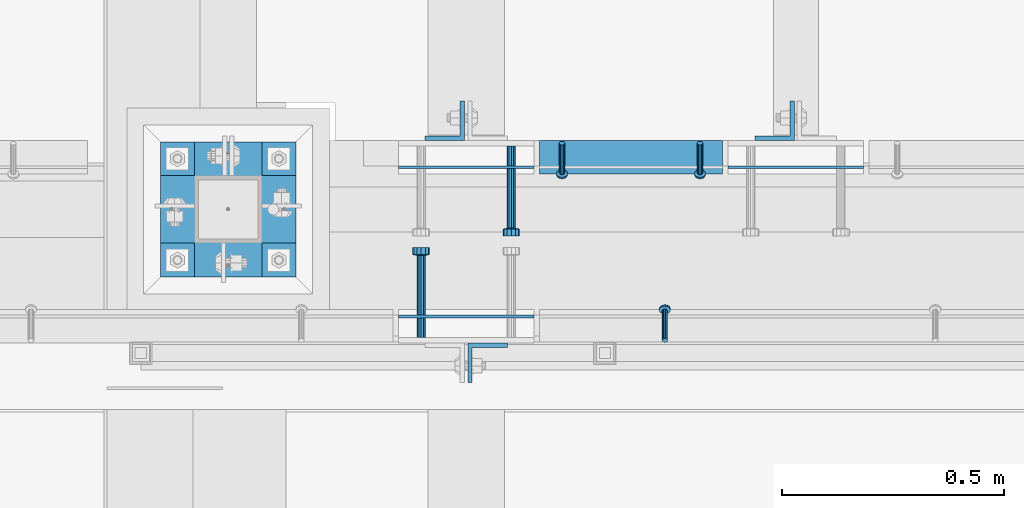
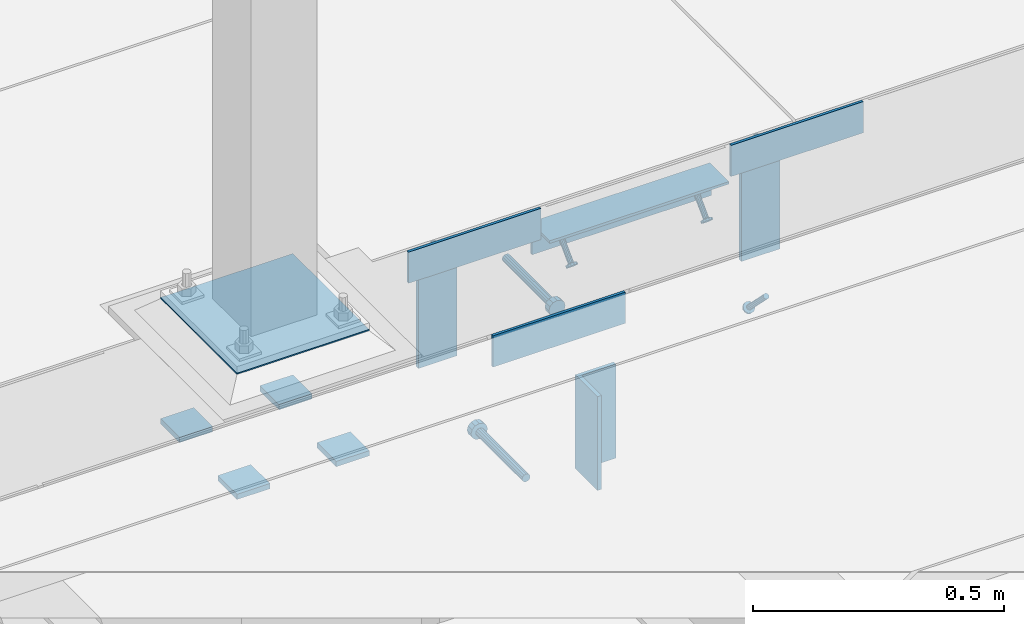
# One storey, part 2066 of 3843: 14 beams, 3 members, 9 elements without a shape of their own.
"""IFC2X3 building model written with IfcOpenShell, lengths in millimetres."""

from ifc_helpers import new_model, si_unit, frame, origin_with_axes, place, context, subcontext, project, spatial, faceted_brep, material, type_object, element, aggregate, save


model = new_model("IFC2X3")

# Units and contexts
model_context = context("Model", 3, precision=1e-05, world=origin_with_axes())
body_context = subcontext(model_context, "Body", "Model", "MODEL_VIEW")
ifc_project = project(units=[si_unit("LENGTHUNIT", "METRE", prefix="MILLI"), si_unit("AREAUNIT", "SQUARE_METRE"), si_unit("VOLUMEUNIT", "CUBIC_METRE"), si_unit("MASSUNIT", "GRAM", prefix="KILO"), si_unit("TIMEUNIT", "SECOND"), si_unit("PLANEANGLEUNIT", "RADIAN"), si_unit("SOLIDANGLEUNIT", "STERADIAN"), si_unit("THERMODYNAMICTEMPERATUREUNIT", "DEGREE_CELSIUS"), si_unit("LUMINOUSINTENSITYUNIT", "LUMEN")], contexts=[model_context])

# Site, building, storey
site_placement = place(None, origin_with_axes())
site = spatial("IfcSite", under=ifc_project, at=site_placement, CompositionType="ELEMENT")
building_placement = place(site_placement, origin_with_axes())
building = spatial("IfcBuilding", under=site, at=building_placement, Name="Undefined", CompositionType="ELEMENT")
storey_placement = place(building_placement, origin_with_axes())
storey = spatial("IfcBuildingStorey", under=building, at=storey_placement, Name="Undefined", CompositionType="ELEMENT", Elevation=0.0)

# Assembly, member
assembly_1_placement = place(storey_placement, origin_with_axes())
assembly_1 = element("IfcElementAssembly", 1, at=assembly_1_placement, inside=storey, Name="ANGLE", AssemblyPlace="NOTDEFINED", PredefinedType="RIGID_FRAME")
ifc_material_1 = material(Name="STEEL/A108")
member_type = type_object("IfcMemberType", PredefinedType="NOTDEFINED")
member_1_placement = place(assembly_1_placement, frame((49980.8497619755, 20012.0250010032, 30397.4500030497), z_axis=(-1.0, 0.0, 0.0), x_axis=(5.70000238222118e-08, 0.707106781186546, -0.707106781186546)))
member_1 = element("IfcMember", 2, at=member_1_placement, type_object=member_type, material=ifc_material_1, Name="HEADED STUD ANCHOR", context=body_context, shape_type="Brep", body=[
    faceted_brep([(7.27595761418343e-12, -3.18000006675175, 5.5), (0.0, -5.49999999998363, 3.1800000667572), (94.4879985803855, -5.50000000011278, 3.1800000667572), (94.4879985803782, -3.18000006687362, 5.5), (0.0, -6.3499999046162, 0.0), (94.4879985803855, -6.34999990474535, 0.0), (0.0, -5.49999999998363, -3.1800000667572), (94.4879985803855, -5.50000000011278, -3.1800000667572), (7.27595761418343e-12, -3.18000006675175, -5.5), (94.4879985803782, -3.18000006687362, -5.5), (7.27595761418343e-12, -1.81898940354586e-12, -6.34999990463257), (94.4879985803782, -1.20053300634027e-10, -6.34999990463257), (0.0, 3.18000006675175, -5.5), (94.4879985803709, 3.18000006663351, -5.5), (7.27595761418343e-12, 5.49999999998363, -3.1800000667572), (94.4879985803709, 5.49999999987267, -3.1800000667572), (7.27595761418343e-12, 6.3499999046162, 0.0), (94.4879985803673, 6.34999990450706, 0.0), (7.27595761418343e-12, 5.49999999998363, 3.1800000667572), (94.4879985803709, 5.49999999987267, 3.1800000667572), (0.0, 3.18000006675175, 5.5), (94.4879985803709, 3.18000006663351, 5.5), (7.27595761418343e-12, -1.81898940354586e-12, 6.34999990463257), (94.4879985803782, -1.20053300634027e-10, 6.34999990463257), (96.5199985498621, -10.9899997712273, 6.34999990463257), (96.5199985498548, -6.34000015270249, 10.9899997711182), (96.5199985498621, -12.6999998093743, 0.0), (96.5199985498621, -10.9899997712273, -6.34999990463257), (96.5199985498548, -6.34000015270249, -10.9899997711182), (96.5199985498475, -1.21872290037572e-10, -12.6899995803833), (96.5199985498402, 6.34000015245874, -10.9899997711182), (96.519998549833, 10.9899997709817, -6.34999990463257), (96.519998549833, 12.6999998091305, 0.0), (96.519998549833, 10.9899997709817, 6.34999990463257), (96.5199985498402, 6.34000015245874, 10.9899997711182), (96.5199985498475, -1.21872290037572e-10, 12.6899995803833), (101.599998473539, -10.9899997712328, 6.34999990463257), (101.599998473532, -6.34000015270976, 10.9899997711182), (101.599998473539, -12.6999998093797, 0.0), (101.599998473539, -10.9899997712328, -6.34999990463257), (101.599998473532, -6.34000015270976, -10.9899997711182), (101.599998473524, -1.29148247651756e-10, -12.6899995803833), (101.599998473517, 6.34000015245329, -10.9899997711182), (101.59999847351, 10.9899997709763, -6.34999990463257), (101.599998473503, 12.6999998091196, 0.0), (101.59999847351, 10.9899997709763, 6.34999990463257), (101.599998473517, 6.34000015245329, 10.9899997711182), (101.599998473524, -1.29148247651756e-10, 12.6899995803833)], [[[0, 1, 2, 3]], [[1, 4, 5, 2]], [[4, 6, 7, 5]], [[6, 8, 9, 7]], [[8, 10, 11, 9]], [[10, 12, 13, 11]], [[12, 14, 15, 13]], [[14, 16, 17, 15]], [[16, 18, 19, 17]], [[18, 20, 21, 19]], [[20, 22, 23, 21]], [[22, 0, 3, 23]], [[22, 20, 18, 16, 14, 12, 10, 8, 6, 4, 1, 0]], [[3, 2, 24, 25]], [[2, 5, 26, 24]], [[5, 7, 27, 26]], [[7, 9, 28, 27]], [[9, 11, 29, 28]], [[11, 13, 30, 29]], [[13, 15, 31, 30]], [[15, 17, 32, 31]], [[17, 19, 33, 32]], [[19, 21, 34, 33]], [[21, 23, 35, 34]], [[23, 3, 25, 35]], [[25, 24, 36, 37]], [[24, 26, 38, 36]], [[26, 27, 39, 38]], [[27, 28, 40, 39]], [[28, 29, 41, 40]], [[29, 30, 42, 41]], [[30, 31, 43, 42]], [[31, 32, 44, 43]], [[32, 33, 45, 44]], [[33, 34, 46, 45]], [[34, 35, 47, 46]], [[35, 25, 37, 47]], [[38, 39, 40, 41, 42, 43, 44, 45, 46, 47, 37, 36]]]),
])
aggregate(assembly_1, [member_1])

# Assembly, members
assembly_2_placement = place(storey_placement, origin_with_axes())
assembly_2 = element("IfcElementAssembly", 3, at=assembly_2_placement, inside=storey, Name="ANGLE", AssemblyPlace="NOTDEFINED", PredefinedType="RIGID_FRAME")
member_2_placement = place(assembly_2_placement, frame((49749.0749969224, 20456.5247895468, 30397.4500030518), z_axis=(1.0, 0.0, 0.0), x_axis=(0.0, -0.707106781186548, -0.707106781186548)))
member_2 = element("IfcMember", 4, at=member_2_placement, type_object=member_type, material=ifc_material_1, Name="HEADED STUD ANCHOR", context=body_context, shape_type="Brep", body=[
    faceted_brep([(7.27595761418343e-12, -3.18000006675175, 5.5), (0.0, -5.49999999998363, 3.1800000667572), (94.4879985803855, -5.50000000011278, 3.1800000667572), (94.4879985803782, -3.18000006687362, 5.5), (0.0, -6.3499999046162, 0.0), (94.4879985803855, -6.34999990474535, 0.0), (0.0, -5.49999999998363, -3.1800000667572), (94.4879985803855, -5.50000000011278, -3.1800000667572), (7.27595761418343e-12, -3.18000006675175, -5.5), (94.4879985803782, -3.18000006687362, -5.5), (7.27595761418343e-12, -1.81898940354586e-12, -6.34999990463257), (94.4879985803782, -1.20053300634027e-10, -6.34999990463257), (0.0, 3.18000006675175, -5.5), (94.4879985803709, 3.18000006663351, -5.5), (7.27595761418343e-12, 5.49999999998363, -3.1800000667572), (94.4879985803709, 5.49999999987267, -3.1800000667572), (7.27595761418343e-12, 6.3499999046162, 0.0), (94.4879985803673, 6.34999990450706, 0.0), (7.27595761418343e-12, 5.49999999998363, 3.1800000667572), (94.4879985803709, 5.49999999987267, 3.1800000667572), (0.0, 3.18000006675175, 5.5), (94.4879985803709, 3.18000006663351, 5.5), (7.27595761418343e-12, -1.81898940354586e-12, 6.34999990463257), (94.4879985803782, -1.20053300634027e-10, 6.34999990463257), (96.5199985498621, -10.9899997712273, 6.34999990463257), (96.5199985498548, -6.34000015270249, 10.9899997711182), (96.5199985498621, -12.6999998093743, 0.0), (96.5199985498621, -10.9899997712273, -6.34999990463257), (96.5199985498548, -6.34000015270249, -10.9899997711182), (96.5199985498475, -1.21872290037572e-10, -12.6899995803833), (96.5199985498402, 6.34000015245874, -10.9899997711182), (96.519998549833, 10.9899997709817, -6.34999990463257), (96.519998549833, 12.6999998091305, 0.0), (96.519998549833, 10.9899997709817, 6.34999990463257), (96.5199985498402, 6.34000015245874, 10.9899997711182), (96.5199985498475, -1.21872290037572e-10, 12.6899995803833), (101.599998473539, -10.9899997712328, 6.34999990463257), (101.599998473532, -6.34000015270976, 10.9899997711182), (101.599998473539, -12.6999998093797, 0.0), (101.599998473539, -10.9899997712328, -6.34999990463257), (101.599998473532, -6.34000015270976, -10.9899997711182), (101.599998473524, -1.29148247651756e-10, -12.6899995803833), (101.599998473517, 6.34000015245329, -10.9899997711182), (101.59999847351, 10.9899997709763, -6.34999990463257), (101.599998473503, 12.6999998091196, 0.0), (101.59999847351, 10.9899997709763, 6.34999990463257), (101.599998473517, 6.34000015245329, 10.9899997711182), (101.599998473524, -1.29148247651756e-10, 12.6899995803833)], [[[0, 1, 2, 3]], [[1, 4, 5, 2]], [[4, 6, 7, 5]], [[6, 8, 9, 7]], [[8, 10, 11, 9]], [[10, 12, 13, 11]], [[12, 14, 15, 13]], [[14, 16, 17, 15]], [[16, 18, 19, 17]], [[18, 20, 21, 19]], [[20, 22, 23, 21]], [[22, 0, 3, 23]], [[22, 20, 18, 16, 14, 12, 10, 8, 6, 4, 1, 0]], [[3, 2, 24, 25]], [[2, 5, 26, 24]], [[5, 7, 27, 26]], [[7, 9, 28, 27]], [[9, 11, 29, 28]], [[11, 13, 30, 29]], [[13, 15, 31, 30]], [[15, 17, 32, 31]], [[17, 19, 33, 32]], [[19, 21, 34, 33]], [[21, 23, 35, 34]], [[23, 3, 25, 35]], [[25, 24, 36, 37]], [[24, 26, 38, 36]], [[26, 27, 39, 38]], [[27, 28, 40, 39]], [[28, 29, 41, 40]], [[29, 30, 42, 41]], [[30, 31, 43, 42]], [[31, 32, 44, 43]], [[32, 33, 45, 44]], [[33, 34, 46, 45]], [[34, 35, 47, 46]], [[35, 25, 37, 47]], [[38, 39, 40, 41, 42, 43, 44, 45, 46, 47, 37, 36]]]),
])
member_3_placement = place(assembly_2_placement, frame((50060.2249969224, 20456.524782038, 30397.4500030518), z_axis=(1.0, 0.0, 0.0), x_axis=(0.0, -0.707106781186548, -0.707106781186548)))
member_3 = element("IfcMember", 5, at=member_3_placement, type_object=member_type, material=ifc_material_1, Name="HEADED STUD ANCHOR", context=body_context, shape_type="Brep", body=[
    faceted_brep([(7.27595761418343e-12, -3.18000006675175, 5.5), (0.0, -5.49999999998363, 3.1800000667572), (94.4879985803855, -5.50000000011278, 3.1800000667572), (94.4879985803782, -3.18000006687362, 5.5), (0.0, -6.3499999046162, 0.0), (94.4879985803855, -6.34999990474535, 0.0), (0.0, -5.49999999998363, -3.1800000667572), (94.4879985803855, -5.50000000011278, -3.1800000667572), (7.27595761418343e-12, -3.18000006675175, -5.5), (94.4879985803782, -3.18000006687362, -5.5), (7.27595761418343e-12, -1.81898940354586e-12, -6.34999990463257), (94.4879985803782, -1.20053300634027e-10, -6.34999990463257), (0.0, 3.18000006675175, -5.5), (94.4879985803709, 3.18000006663351, -5.5), (7.27595761418343e-12, 5.49999999998363, -3.1800000667572), (94.4879985803709, 5.49999999987267, -3.1800000667572), (7.27595761418343e-12, 6.3499999046162, 0.0), (94.4879985803673, 6.34999990450706, 0.0), (7.27595761418343e-12, 5.49999999998363, 3.1800000667572), (94.4879985803709, 5.49999999987267, 3.1800000667572), (0.0, 3.18000006675175, 5.5), (94.4879985803709, 3.18000006663351, 5.5), (7.27595761418343e-12, -1.81898940354586e-12, 6.34999990463257), (94.4879985803782, -1.20053300634027e-10, 6.34999990463257), (96.5199985498621, -10.9899997712273, 6.34999990463257), (96.5199985498548, -6.34000015270249, 10.9899997711182), (96.5199985498621, -12.6999998093743, 0.0), (96.5199985498621, -10.9899997712273, -6.34999990463257), (96.5199985498548, -6.34000015270249, -10.9899997711182), (96.5199985498475, -1.21872290037572e-10, -12.6899995803833), (96.5199985498402, 6.34000015245874, -10.9899997711182), (96.519998549833, 10.9899997709817, -6.34999990463257), (96.519998549833, 12.6999998091305, 0.0), (96.519998549833, 10.9899997709817, 6.34999990463257), (96.5199985498402, 6.34000015245874, 10.9899997711182), (96.5199985498475, -1.21872290037572e-10, 12.6899995803833), (101.599998473539, -10.9899997712328, 6.34999990463257), (101.599998473532, -6.34000015270976, 10.9899997711182), (101.599998473539, -12.6999998093797, 0.0), (101.599998473539, -10.9899997712328, -6.34999990463257), (101.599998473532, -6.34000015270976, -10.9899997711182), (101.599998473524, -1.29148247651756e-10, -12.6899995803833), (101.599998473517, 6.34000015245329, -10.9899997711182), (101.59999847351, 10.9899997709763, -6.34999990463257), (101.599998473503, 12.6999998091196, 0.0), (101.59999847351, 10.9899997709763, 6.34999990463257), (101.599998473517, 6.34000015245329, 10.9899997711182), (101.599998473524, -1.29148247651756e-10, 12.6899995803833)], [[[0, 1, 2, 3]], [[1, 4, 5, 2]], [[4, 6, 7, 5]], [[6, 8, 9, 7]], [[8, 10, 11, 9]], [[10, 12, 13, 11]], [[12, 14, 15, 13]], [[14, 16, 17, 15]], [[16, 18, 19, 17]], [[18, 20, 21, 19]], [[20, 22, 23, 21]], [[22, 0, 3, 23]], [[22, 20, 18, 16, 14, 12, 10, 8, 6, 4, 1, 0]], [[3, 2, 24, 25]], [[2, 5, 26, 24]], [[5, 7, 27, 26]], [[7, 9, 28, 27]], [[9, 11, 29, 28]], [[11, 13, 30, 29]], [[13, 15, 31, 30]], [[15, 17, 32, 31]], [[17, 19, 33, 32]], [[19, 21, 34, 33]], [[21, 23, 35, 34]], [[23, 3, 25, 35]], [[25, 24, 36, 37]], [[24, 26, 38, 36]], [[26, 27, 39, 38]], [[27, 28, 40, 39]], [[28, 29, 41, 40]], [[29, 30, 42, 41]], [[30, 31, 43, 42]], [[31, 32, 44, 43]], [[32, 33, 45, 44]], [[33, 34, 46, 45]], [[34, 35, 47, 46]], [[35, 25, 37, 47]], [[38, 39, 40, 41, 42, 43, 44, 45, 46, 47, 37, 36]]]),
])

# Assembly, beam
assembly_3_placement = place(storey_placement, origin_with_axes())
assembly_3 = element("IfcElementAssembly", 6, at=assembly_3_placement, inside=storey, Name="EMBED PLATE", AssemblyPlace="NOTDEFINED", PredefinedType="RIGID_FRAME")
ifc_material_2 = material(Name="STEEL/A36")
beam_type_1 = type_object("IfcBeamType", PredefinedType="NOTDEFINED")
beam_1_placement = place(assembly_3_placement, frame((49380.775, 20065.9999969482, 30441.9), z_axis=(0.0, 0.0, 1.0), x_axis=(1.0, 0.0, 0.0)))
beam_1 = element("IfcBeam", 7, at=beam_1_placement, type_object=beam_type_1, material=ifc_material_2, Name="PLATE", context=body_context, shape_type="Brep", body=[
    faceted_brep([(0.0, 3.17500000000291, -38.0999999999985), (0.0, 3.17500000000291, 38.0999999999985), (304.800000000003, 3.17499999999927, 38.0999999999985), (304.800000000003, 3.17499999999927, -38.0999999999985), (0.0, -3.17500000000291, 38.0999999999985), (304.800000000003, -3.17499999999927, 38.0999999999985), (0.0, -3.17500000000291, -38.0999999999985), (304.800000000003, -3.17499999999927, -38.0999999999985)], [[[0, 1, 2, 3]], [[1, 4, 5, 2]], [[4, 6, 7, 5]], [[6, 0, 3, 7]], [[5, 7, 3, 2]], [[6, 4, 1, 0]]]),
])

assembly_4_placement = place(storey_placement, origin_with_axes())
assembly_4 = element("IfcElementAssembly", 8, at=assembly_4_placement, inside=storey, Name="EMBED PLATE", AssemblyPlace="NOTDEFINED", PredefinedType="RIGID_FRAME")
beam_2_placement = place(assembly_4_placement, frame((50428.525, 20402.5500030518, 30441.9), z_axis=(0.0, 0.0, 1.0), x_axis=(-1.0, 0.0, 0.0)))
beam_2 = element("IfcBeam", 9, at=beam_2_placement, type_object=beam_type_1, material=ifc_material_2, Name="PLATE", context=body_context, shape_type="Brep", body=[
    faceted_brep([(0.0, 3.17500000000291, -38.0999999999985), (0.0, 3.17500000000291, 38.0999999999985), (304.800000000003, 3.17499999999927, 38.0999999999985), (304.800000000003, 3.17499999999927, -38.0999999999985), (0.0, -3.17500000000291, 38.0999999999985), (304.800000000003, -3.17499999999927, 38.0999999999985), (0.0, -3.17500000000291, -38.0999999999985), (304.800000000003, -3.17499999999927, -38.0999999999985)], [[[0, 1, 2, 3]], [[1, 4, 5, 2]], [[4, 6, 7, 5]], [[6, 0, 3, 7]], [[5, 7, 3, 2]], [[6, 4, 1, 0]]]),
])
aggregate(assembly_4, [beam_2])

assembly_5_placement = place(storey_placement, origin_with_axes())
assembly_5 = element("IfcElementAssembly", 10, at=assembly_5_placement, inside=storey, Name="EMBED PLATE", AssemblyPlace="NOTDEFINED", PredefinedType="RIGID_FRAME")
beam_3_placement = place(assembly_5_placement, frame((49685.575, 20402.5500030518, 30441.9), z_axis=(0.0, 0.0, 1.0), x_axis=(-1.0, 0.0, 0.0)))
beam_3 = element("IfcBeam", 11, at=beam_3_placement, type_object=beam_type_1, material=ifc_material_2, Name="PLATE", context=body_context, shape_type="Brep", body=[
    faceted_brep([(0.0, 3.17500000000291, -38.0999999999985), (0.0, 3.17500000000291, 38.0999999999985), (304.800000000003, 3.17499999999927, 38.0999999999985), (304.800000000003, 3.17499999999927, -38.0999999999985), (0.0, -3.17500000000291, 38.0999999999985), (304.800000000003, -3.17499999999927, 38.0999999999985), (0.0, -3.17500000000291, -38.0999999999985), (304.800000000003, -3.17499999999927, -38.0999999999985)], [[[0, 1, 2, 3]], [[1, 4, 5, 2]], [[4, 6, 7, 5]], [[6, 0, 3, 7]], [[5, 7, 3, 2]], [[6, 4, 1, 0]]]),
])

# Beam
beam_type_2 = type_object("IfcBeamType", Name="L3X3X1/4", PredefinedType="NOTDEFINED")
beam_4_placement = place(assembly_2_placement, frame((50111.0249771283, 20424.7747522355, 30365.7000030518), z_axis=(0.0, 0.0, -1.0), x_axis=(-1.0, 0.0, 0.0)))
beam_4 = element("IfcBeam", 12, at=beam_4_placement, type_object=beam_type_2, material=ifc_material_2, Name="ANGLE", ObjectType="L3X3X1/4", context=body_context, shape_type="Brep", body=[
    faceted_brep([(0.0, 38.0999999999985, -38.0999999999985), (0.0, 38.0999999999985, 38.0999999999985), (412.750000001892, 38.0999999996438, 38.0999999999985), (412.750000001892, 38.0999999996438, -38.0999999999985), (0.0, 31.75, 38.0999999999985), (412.75000000187, 31.7499999996417, 38.0999999999985), (0.0, 31.75, -31.75), (412.75000000187, 31.7499999996417, -31.75), (0.0, -38.0999999999985, -31.75), (412.750000001688, -38.1000000003733, -31.75), (0.0, -38.0999999999985, -38.0999999999985), (412.750000001688, -38.1000000003733, -38.0999999999985)], [[[0, 1, 2, 3]], [[1, 4, 5, 2]], [[4, 6, 7, 5]], [[6, 8, 9, 7]], [[8, 10, 11, 9]], [[10, 0, 3, 11]], [[5, 7, 9, 11, 3, 2]], [[10, 8, 6, 4, 1, 0]]]),
])

aggregate(assembly_2, [member_2, member_3, beam_4])

# Assembly, beam
assembly_6_placement = place(storey_placement, origin_with_axes())
assembly_6 = element("IfcElementAssembly", 13, at=assembly_6_placement, inside=storey, Name="BEAM", AssemblyPlace="NOTDEFINED", PredefinedType="RIGID_FRAME")
beam_type_3 = type_object("IfcBeamType", Name="L3-1/2X3-1/2X3/8", PredefinedType="NOTDEFINED")
beam_5_placement = place(assembly_6_placement, frame((50228.5, 20507.3250030517, 30365.7), z_axis=(-1.0, 0.0, 0.0), x_axis=(0.0, 0.0, -1.0)))
beam_5 = element("IfcBeam", 14, at=beam_5_placement, type_object=beam_type_3, material=ifc_material_2, Name="ANGLE", ObjectType="L3-1/2X3-1/2X3/8", context=body_context, shape_type="Brep", body=[
    faceted_brep([(-3.63797880709171e-12, 44.4499999999971, -44.4500000000007), (-3.63797880709171e-12, 44.4499999999971, 44.4500000000007), (228.600000000006, 44.4499999999971, 44.4500000000007), (228.600000000006, 44.4499999999971, -44.4500000000007), (0.0, 34.9250000000029, 44.4500000000007), (228.600000000006, 34.9250000000029, 44.4500000000007), (0.0, 34.9250000000029, -34.9250000000029), (228.600000000006, 34.9250000000029, -34.9249999999993), (0.0, -44.4499999999971, -34.9249999999993), (228.600000000006, -44.4499999999971, -34.9249999999993), (3.63797880709171e-12, -44.4499999999971, -44.4500000000007), (228.600000000006, -44.4499999999971, -44.4500000000007)], [[[0, 1, 2, 3]], [[1, 4, 5, 2]], [[4, 6, 7, 5]], [[6, 8, 9, 7]], [[8, 10, 11, 9]], [[10, 0, 3, 11]], [[5, 7, 9, 11, 3, 2]], [[10, 8, 6, 4, 1, 0]]]),
])
aggregate(assembly_6, [beam_5])

assembly_7_placement = place(storey_placement, origin_with_axes())
assembly_7 = element("IfcElementAssembly", 15, at=assembly_7_placement, inside=storey, Name="BEAM", AssemblyPlace="NOTDEFINED", PredefinedType="RIGID_FRAME")
beam_6_placement = place(assembly_7_placement, frame((49484.75625, 20507.3250030517, 30365.7), z_axis=(-1.0, 0.0, 0.0), x_axis=(0.0, 0.0, -1.0)))
beam_6 = element("IfcBeam", 16, at=beam_6_placement, type_object=beam_type_3, material=ifc_material_2, Name="ANGLE", ObjectType="L3-1/2X3-1/2X3/8", context=body_context, shape_type="Brep", body=[
    faceted_brep([(-3.63797880709171e-12, 44.4499999999971, -44.4500000000007), (-3.63797880709171e-12, 44.4499999999971, 44.4500000000007), (228.600000000006, 44.4499999999971, 44.4500000000007), (228.600000000006, 44.4499999999971, -44.4500000000007), (0.0, 34.9250000000029, 44.4500000000007), (228.600000000006, 34.9250000000029, 44.4500000000007), (0.0, 34.9250000000029, -34.9250000000029), (228.600000000006, 34.9250000000029, -34.9249999999993), (0.0, -44.4499999999971, -34.9249999999993), (228.600000000006, -44.4499999999971, -34.9249999999993), (3.63797880709171e-12, -44.4499999999971, -44.4500000000007), (228.600000000006, -44.4499999999971, -44.4500000000007)], [[[0, 1, 2, 3]], [[1, 4, 5, 2]], [[4, 6, 7, 5]], [[6, 8, 9, 7]], [[8, 10, 11, 9]], [[10, 0, 3, 11]], [[5, 7, 9, 11, 3, 2]], [[10, 8, 6, 4, 1, 0]]]),
])
aggregate(assembly_7, [beam_6])

assembly_8_placement = place(storey_placement, origin_with_axes())
assembly_8 = element("IfcElementAssembly", 17, at=assembly_8_placement, inside=storey, Name="BEAM", AssemblyPlace="NOTDEFINED", PredefinedType="RIGID_FRAME")
beam_7_placement = place(assembly_8_placement, frame((49581.59375, 19961.2249969482, 30365.7), z_axis=(1.0, 0.0, 0.0), x_axis=(0.0, 0.0, -1.0)))
beam_7 = element("IfcBeam", 18, at=beam_7_placement, type_object=beam_type_3, material=ifc_material_2, Name="ANGLE", ObjectType="L3-1/2X3-1/2X3/8", context=body_context, shape_type="Brep", body=[
    faceted_brep([(-3.63797880709171e-12, 44.4499999999971, -44.4500000000007), (-3.63797880709171e-12, 44.4499999999971, 44.4500000000007), (228.600000000006, 44.4499999999971, 44.4500000000007), (228.600000000006, 44.4499999999971, -44.4500000000007), (0.0, 34.9250000000029, 44.4500000000007), (228.600000000006, 34.9250000000029, 44.4500000000007), (0.0, 34.9250000000029, -34.9250000000029), (228.600000000006, 34.9250000000029, -34.9249999999993), (0.0, -44.4499999999971, -34.9249999999993), (228.600000000006, -44.4499999999971, -34.9249999999993), (3.63797880709171e-12, -44.4499999999971, -44.4500000000007), (228.600000000006, -44.4499999999971, -44.4500000000007)], [[[0, 1, 2, 3]], [[1, 4, 5, 2]], [[4, 6, 7, 5]], [[6, 8, 9, 7]], [[8, 10, 11, 9]], [[10, 0, 3, 11]], [[5, 7, 9, 11, 3, 2]], [[10, 8, 6, 4, 1, 0]]]),
])
aggregate(assembly_8, [beam_7])

# Beam
beam_type_4 = type_object("IfcBeamType", PredefinedType="NOTDEFINED")
beam_8_placement = place(assembly_5_placement, frame((49634.775, 20450.1750030517, 30346.65), z_axis=(1.0, 0.0, 0.0), x_axis=(0.0, -1.0, 0.0)))
beam_8 = element("IfcBeam", 19, at=beam_8_placement, type_object=beam_type_4, material=ifc_material_1, Name="HEADED STUD ANCHOR", context=body_context, shape_type="Brep", body=[
    faceted_brep([(0.0, -9.52000045776367, 0.0), (0.0, -8.25, -4.76000022888184), (184.912000000004, -8.25, -4.76000022888184), (184.912000000004, -9.52000045776367, 0.0), (0.0, -4.76000022888184, -8.25), (184.912000000004, -4.76000022888184, -8.25), (0.0, 0.0, -9.52000045776367), (184.912000000004, 0.0, -9.52000045776367), (0.0, 4.76000022888184, -8.25), (184.912000000004, 4.76000022888184, -8.25), (0.0, 8.25, -4.76000022888184), (184.912000000004, 8.25, -4.76000022888184), (0.0, 9.52000045776367, 0.0), (184.912000000004, 9.52000045776367, 0.0), (0.0, 8.25, 4.76000022888184), (184.912000000004, 8.25, 4.76000022888184), (0.0, 4.76000022888184, 8.25), (184.912000000004, 4.76000022888184, 8.25), (0.0, 0.0, 9.52000045776367), (184.912000000004, 0.0, 9.52000045776367), (0.0, -4.76000022888184, 8.25), (184.912000000004, -4.76000022888184, 8.25), (0.0, -8.25, 4.76000022888184), (184.912000000004, -8.25, 4.76000022888184), (186.944000000003, -16.5, -9.52000045776367), (186.944000000003, -19.0499992370605, 0.0), (186.944000000003, -9.52000045776367, -16.5), (186.944000000003, 0.0, -19.0499992370605), (186.944000000003, 9.52000045776367, -16.5), (186.944000000003, 16.5, -9.52000045776367), (186.944000000003, 19.0499992370605, 0.0), (186.944000000003, 16.5, 9.52000045776367), (186.944000000003, 9.52000045776367, 16.5), (186.944000000003, 0.0, 19.0499992370605), (186.944000000003, -9.52000045776367, 16.5), (186.944000000003, -16.5, 9.52000045776367), (203.199999999997, -16.5, -9.52000045776367), (203.199999999997, -19.0499992370605, 0.0), (203.199999999997, -9.52000045776367, -16.5), (203.199999999997, 0.0, -19.0499992370605), (203.199999999997, 9.52000045776367, -16.5), (203.199999999997, 16.5, -9.52000045776367), (203.199999999997, 19.0499992370605, 0.0), (203.199999999997, 16.5, 9.52000045776367), (203.199999999997, 9.52000045776367, 16.5), (203.199999999997, 0.0, 19.0499992370605), (203.199999999997, -9.52000045776367, 16.5), (203.199999999997, -16.5, 9.52000045776367)], [[[0, 1, 2, 3]], [[1, 4, 5, 2]], [[4, 6, 7, 5]], [[6, 8, 9, 7]], [[8, 10, 11, 9]], [[10, 12, 13, 11]], [[12, 14, 15, 13]], [[14, 16, 17, 15]], [[16, 18, 19, 17]], [[18, 20, 21, 19]], [[20, 22, 23, 21]], [[22, 0, 3, 23]], [[22, 20, 18, 16, 14, 12, 10, 8, 6, 4, 1, 0]], [[3, 2, 24, 25]], [[2, 5, 26, 24]], [[5, 7, 27, 26]], [[7, 9, 28, 27]], [[9, 11, 29, 28]], [[11, 13, 30, 29]], [[13, 15, 31, 30]], [[15, 17, 32, 31]], [[17, 19, 33, 32]], [[19, 21, 34, 33]], [[21, 23, 35, 34]], [[23, 3, 25, 35]], [[25, 24, 36, 37]], [[24, 26, 38, 36]], [[26, 27, 39, 38]], [[27, 28, 40, 39]], [[28, 29, 41, 40]], [[29, 30, 42, 41]], [[30, 31, 43, 42]], [[31, 32, 44, 43]], [[32, 33, 45, 44]], [[33, 34, 46, 45]], [[34, 35, 47, 46]], [[35, 25, 37, 47]], [[38, 39, 40, 41, 42, 43, 44, 45, 46, 47, 37, 36]]]),
])

aggregate(assembly_5, [beam_3, beam_8])

beam_9_placement = place(assembly_3_placement, frame((49431.575, 20018.3749969482, 30143.45), z_axis=(-1.0, 0.0, 0.0), x_axis=(0.0, 1.0, 0.0)))
beam_9 = element("IfcBeam", 20, at=beam_9_placement, type_object=beam_type_4, material=ifc_material_1, Name="HEADED STUD ANCHOR", context=body_context, shape_type="Brep", body=[
    faceted_brep([(0.0, -9.52000045776367, 0.0), (0.0, -8.25, -4.76000022888184), (184.912000000004, -8.25, -4.76000022888184), (184.912000000004, -9.52000045776367, 0.0), (0.0, -4.76000022888184, -8.25), (184.912000000004, -4.76000022888184, -8.25), (0.0, 0.0, -9.52000045776367), (184.912000000004, 0.0, -9.52000045776367), (0.0, 4.76000022888184, -8.25), (184.912000000004, 4.76000022888184, -8.25), (0.0, 8.25, -4.76000022888184), (184.912000000004, 8.25, -4.76000022888184), (0.0, 9.52000045776367, 0.0), (184.912000000004, 9.52000045776367, 0.0), (0.0, 8.25, 4.76000022888184), (184.912000000004, 8.25, 4.76000022888184), (0.0, 4.76000022888184, 8.25), (184.912000000004, 4.76000022888184, 8.25), (0.0, 0.0, 9.52000045776367), (184.912000000004, 0.0, 9.52000045776367), (0.0, -4.76000022888184, 8.25), (184.912000000004, -4.76000022888184, 8.25), (0.0, -8.25, 4.76000022888184), (184.912000000004, -8.25, 4.76000022888184), (186.944000000003, -16.5, -9.52000045776367), (186.944000000003, -19.0499992370605, 0.0), (186.944000000003, -9.52000045776367, -16.5), (186.944000000003, 0.0, -19.0499992370605), (186.944000000003, 9.52000045776367, -16.5), (186.944000000003, 16.5, -9.52000045776367), (186.944000000003, 19.0499992370605, 0.0), (186.944000000003, 16.5, 9.52000045776367), (186.944000000003, 9.52000045776367, 16.5), (186.944000000003, 0.0, 19.0499992370605), (186.944000000003, -9.52000045776367, 16.5), (186.944000000003, -16.5, 9.52000045776367), (203.199999999997, -16.5, -9.52000045776367), (203.199999999997, -19.0499992370605, 0.0), (203.199999999997, -9.52000045776367, -16.5), (203.199999999997, 0.0, -19.0499992370605), (203.199999999997, 9.52000045776367, -16.5), (203.199999999997, 16.5, -9.52000045776367), (203.199999999997, 19.0499992370605, 0.0), (203.199999999997, 16.5, 9.52000045776367), (203.199999999997, 9.52000045776367, 16.5), (203.199999999997, 0.0, 19.0499992370605), (203.199999999997, -9.52000045776367, 16.5), (203.199999999997, -16.5, 9.52000045776367)], [[[0, 1, 2, 3]], [[1, 4, 5, 2]], [[4, 6, 7, 5]], [[6, 8, 9, 7]], [[8, 10, 11, 9]], [[10, 12, 13, 11]], [[12, 14, 15, 13]], [[14, 16, 17, 15]], [[16, 18, 19, 17]], [[18, 20, 21, 19]], [[20, 22, 23, 21]], [[22, 0, 3, 23]], [[22, 20, 18, 16, 14, 12, 10, 8, 6, 4, 1, 0]], [[3, 2, 24, 25]], [[2, 5, 26, 24]], [[5, 7, 27, 26]], [[7, 9, 28, 27]], [[9, 11, 29, 28]], [[11, 13, 30, 29]], [[13, 15, 31, 30]], [[15, 17, 32, 31]], [[17, 19, 33, 32]], [[19, 21, 34, 33]], [[21, 23, 35, 34]], [[23, 3, 25, 35]], [[25, 24, 36, 37]], [[24, 26, 38, 36]], [[26, 27, 39, 38]], [[27, 28, 40, 39]], [[28, 29, 41, 40]], [[29, 30, 42, 41]], [[30, 31, 43, 42]], [[31, 32, 44, 43]], [[32, 33, 45, 44]], [[33, 34, 46, 45]], [[34, 35, 47, 46]], [[35, 25, 37, 47]], [[38, 39, 40, 41, 42, 43, 44, 45, 46, 47, 37, 36]]]),
])

aggregate(assembly_3, [beam_1, beam_9])

# Assembly, beams
assembly_9_placement = place(storey_placement, origin_with_axes())
assembly_9 = element("IfcElementAssembly", 21, at=assembly_9_placement, inside=storey, Name="TEMPLATE", AssemblyPlace="NOTDEFINED", PredefinedType="RIGID_FRAME")
ifc_material_3 = material(Name="STEEL/A572-50")
beam_type_5 = type_object("IfcBeamType", PredefinedType="NOTDEFINED")
beam_10_placement = place(assembly_9_placement, frame((49149.0, 20193.0, 30219.65), z_axis=(0.0, 1.0, 0.0), x_axis=(-1.0, 0.0, 0.0)))
beam_10 = element("IfcBeam", 22, at=beam_10_placement, type_object=beam_type_5, material=ifc_material_3, context=body_context, shape_type="Brep", body=[
    faceted_brep([(0.0, 6.34999999999854, -38.1000000000058), (0.0, 6.34999999999854, 38.0999984741211), (76.1999999999971, 6.34999999999854, 38.1000000000058), (76.1999999999971, 6.34999999999854, -38.1000000000058), (0.0, -6.34999999999854, 38.0999984741211), (76.1999999999971, -6.34999999999854, 38.1000000000058), (0.0, -6.34999999999854, -38.1000000000058), (76.1999999999971, -6.34999999999854, -38.1000000000058)], [[[0, 1, 2, 3]], [[1, 4, 5, 2]], [[4, 6, 7, 5]], [[6, 0, 3, 7]], [[5, 7, 3, 2]], [[6, 4, 1, 0]]]),
])
beam_11_placement = place(assembly_9_placement, frame((49149.0, 20421.6, 30219.65), z_axis=(0.0, 1.0, 0.0), x_axis=(-1.0, 0.0, 0.0)))
beam_11 = element("IfcBeam", 23, at=beam_11_placement, type_object=beam_type_5, material=ifc_material_3, context=body_context, shape_type="Brep", body=[
    faceted_brep([(0.0, 6.34999999999854, -38.1000000000058), (0.0, 6.34999999999854, 38.0999984741211), (76.1999999999971, 6.34999999999854, 38.1000000000058), (76.1999999999971, 6.34999999999854, -38.1000000000058), (0.0, -6.34999999999854, 38.0999984741211), (76.1999999999971, -6.34999999999854, 38.1000000000058), (0.0, -6.34999999999854, -38.1000000000058), (76.1999999999971, -6.34999999999854, -38.1000000000058)], [[[0, 1, 2, 3]], [[1, 4, 5, 2]], [[4, 6, 7, 5]], [[6, 0, 3, 7]], [[5, 7, 3, 2]], [[6, 4, 1, 0]]]),
])
beam_12_placement = place(assembly_9_placement, frame((48920.4, 20193.0, 30219.65), z_axis=(0.0, 1.0, 0.0), x_axis=(-1.0, 0.0, 0.0)))
beam_12 = element("IfcBeam", 24, at=beam_12_placement, type_object=beam_type_5, material=ifc_material_3, context=body_context, shape_type="Brep", body=[
    faceted_brep([(0.0, 6.34999999999854, -38.1000000000058), (0.0, 6.34999999999854, 38.0999984741211), (76.1999999999971, 6.34999999999854, 38.1000000000058), (76.1999999999971, 6.34999999999854, -38.1000000000058), (0.0, -6.34999999999854, 38.0999984741211), (76.1999999999971, -6.34999999999854, 38.1000000000058), (0.0, -6.34999999999854, -38.1000000000058), (76.1999999999971, -6.34999999999854, -38.1000000000058)], [[[0, 1, 2, 3]], [[1, 4, 5, 2]], [[4, 6, 7, 5]], [[6, 0, 3, 7]], [[5, 7, 3, 2]], [[6, 4, 1, 0]]]),
])
beam_13_placement = place(assembly_9_placement, frame((48920.4, 20421.6, 30219.65), z_axis=(0.0, 1.0, 0.0), x_axis=(-1.0, 0.0, 0.0)))
beam_13 = element("IfcBeam", 25, at=beam_13_placement, type_object=beam_type_5, material=ifc_material_3, context=body_context, shape_type="Brep", body=[
    faceted_brep([(0.0, 6.34999999999854, -38.1000000000058), (0.0, 6.34999999999854, 38.0999984741211), (76.1999999999971, 6.34999999999854, 38.1000000000058), (76.1999999999971, 6.34999999999854, -38.1000000000058), (0.0, -6.34999999999854, 38.0999984741211), (76.1999999999971, -6.34999999999854, 38.1000000000058), (0.0, -6.34999999999854, -38.1000000000058), (76.1999999999971, -6.34999999999854, -38.1000000000058)], [[[0, 1, 2, 3]], [[1, 4, 5, 2]], [[4, 6, 7, 5]], [[6, 0, 3, 7]], [[5, 7, 3, 2]], [[6, 4, 1, 0]]]),
])
beam_type_6 = type_object("IfcBeamType", PredefinedType="NOTDEFINED")
beam_14_placement = place(assembly_9_placement, frame((49148.9999969482, 20307.3, 30519.6875), z_axis=(0.0, -1.0, 0.0), x_axis=(-1.0, 0.0, 0.0)))
beam_14 = element("IfcBeam", 26, at=beam_14_placement, type_object=beam_type_6, material=ifc_material_3, Name="TEMPLATE", context=body_context, shape_type="Brep", body=[
    faceted_brep([(0.0, 1.58750000000146, -152.400000000001), (0.0, 1.58750000000146, 152.400000000001), (304.799993896479, 1.58750000000146, 152.400000000001), (304.799993896479, 1.58750000000146, -152.400000000001), (0.0, -1.58750000000146, 152.400000000001), (304.799993896479, -1.58750000000146, 152.400000000001), (0.0, -1.58750000000146, -152.400000000001), (304.799993896479, -1.58750000000146, -152.400000000001)], [[[0, 1, 2, 3]], [[1, 4, 5, 2]], [[4, 6, 7, 5]], [[6, 0, 3, 7]], [[5, 7, 3, 2]], [[6, 4, 1, 0]]]),
])
aggregate(assembly_9, [beam_10, beam_11, beam_12, beam_13, beam_14])

save(model, "model.ifc")
